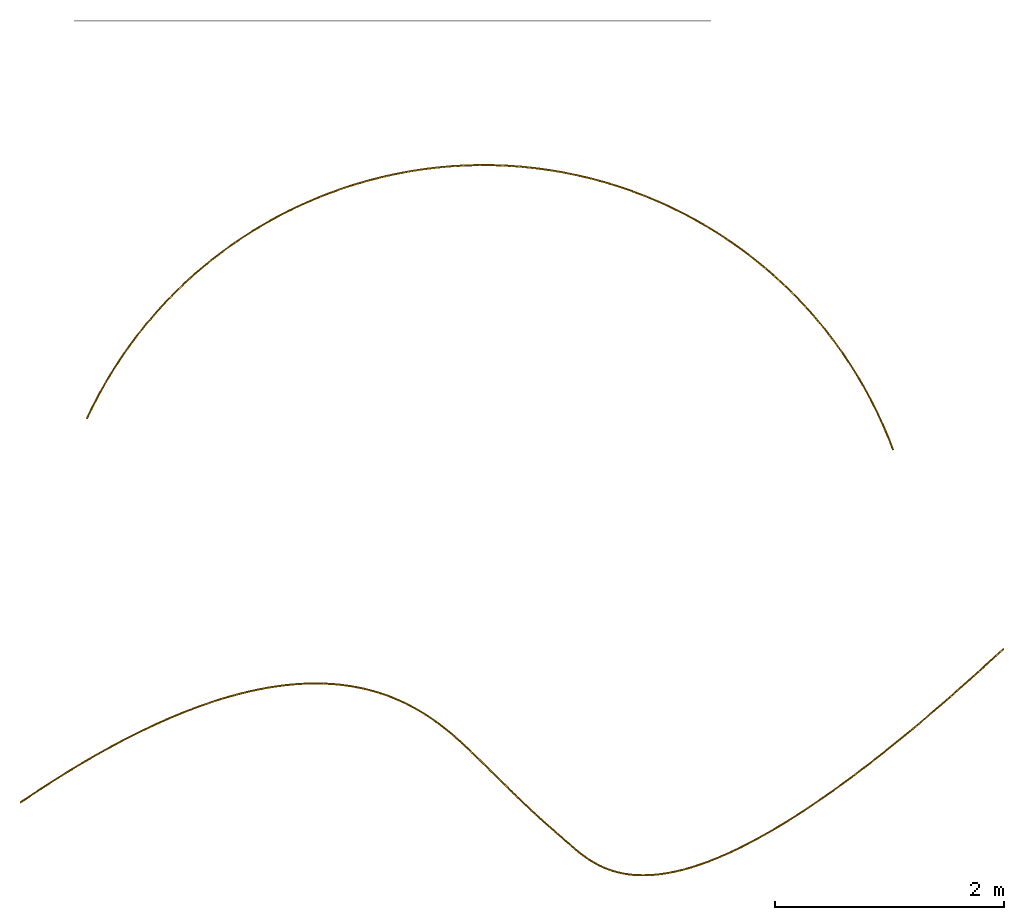
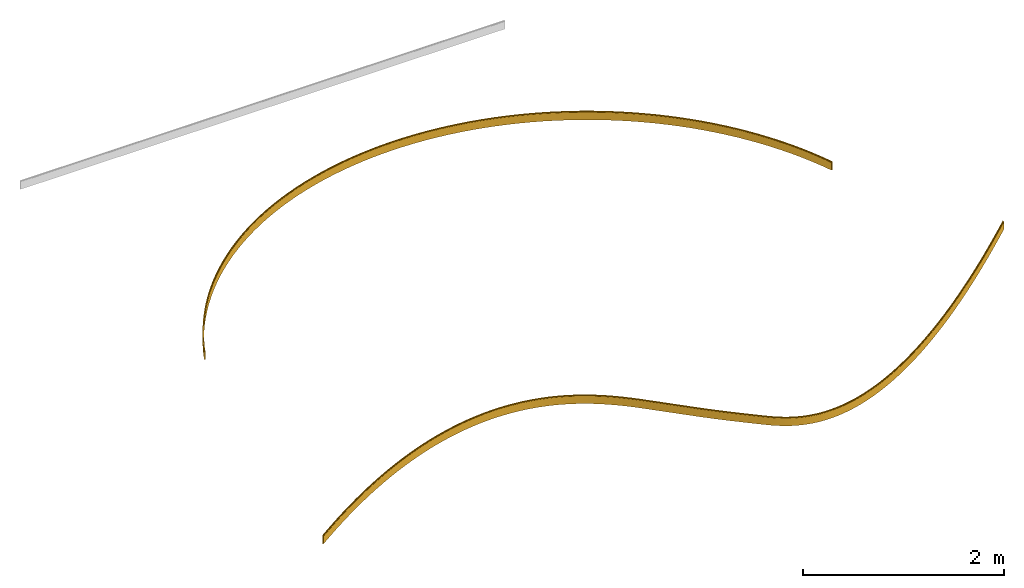
# One storey, part 1 of 2: 2 coverings.
"""IFC2X3 building model written with IfcOpenShell, lengths in feet."""

from ifc_helpers import new_model, entity, si_unit, converted_unit, derived_unit, money_unit, direction, frame, origin_with_axes, place, context, subcontext, project, spatial, material, type_object, element, save


model = new_model("IFC2X3")

# Units and contexts
model_context = context("Model", 3, precision=1e-05, world=origin_with_axes(), true_north=direction((0.0, 1.0)))
body_context = subcontext(model_context, "Body", "Model", "MODEL_VIEW", scale=1.0)
ifc_project = project(units=[converted_unit("LENGTHUNIT", "foot", entity("IfcReal", 30.48), si_unit("LENGTHUNIT", "METRE", prefix="CENTI"), dimensions=[1, 0, 0, 0, 0, 0, 0]), si_unit("AREAUNIT", "SQUARE_METRE"), si_unit("VOLUMEUNIT", "CUBIC_METRE"), si_unit("ABSORBEDDOSEUNIT", "GRAY"), si_unit("AMOUNTOFSUBSTANCEUNIT", "MOLE"), si_unit("DOSEEQUIVALENTUNIT", "SIEVERT"), si_unit("ELECTRICCAPACITANCEUNIT", "FARAD"), si_unit("ELECTRICCHARGEUNIT", "COULOMB"), si_unit("ELECTRICCONDUCTANCEUNIT", "SIEMENS"), si_unit("ELECTRICCURRENTUNIT", "AMPERE"), si_unit("ELECTRICRESISTANCEUNIT", "OHM"), si_unit("ELECTRICVOLTAGEUNIT", "VOLT"), si_unit("ENERGYUNIT", "JOULE"), si_unit("FORCEUNIT", "NEWTON"), si_unit("FREQUENCYUNIT", "HERTZ"), si_unit("ILLUMINANCEUNIT", "LUX"), si_unit("INDUCTANCEUNIT", "HENRY"), si_unit("LUMINOUSFLUXUNIT", "LUMEN"), si_unit("LUMINOUSINTENSITYUNIT", "CANDELA"), si_unit("MAGNETICFLUXDENSITYUNIT", "TESLA"), si_unit("MAGNETICFLUXUNIT", "WEBER"), si_unit("MASSUNIT", "GRAM"), converted_unit("PLANEANGLEUNIT", "degree", entity("IfcReal", 0.0174532925199433), si_unit("PLANEANGLEUNIT", "RADIAN"), dimensions=[0, 0, 0, 0, 0, 0, 0]), si_unit("POWERUNIT", "WATT"), si_unit("PRESSUREUNIT", "PASCAL"), si_unit("RADIOACTIVITYUNIT", "BECQUEREL"), si_unit("SOLIDANGLEUNIT", "STERADIAN"), si_unit("THERMODYNAMICTEMPERATUREUNIT", "KELVIN"), si_unit("TIMEUNIT", "SECOND"), derived_unit("ACCELERATIONUNIT", [(converted_unit("LENGTHUNIT", "foot", entity("IfcReal", 30.48), si_unit("LENGTHUNIT", "METRE", prefix="CENTI"), dimensions=[1, 0, 0, 0, 0, 0, 0]), 1), (si_unit("TIMEUNIT", "SECOND"), -2)]), derived_unit("ANGULARVELOCITYUNIT", [(converted_unit("PLANEANGLEUNIT", "degree", entity("IfcReal", 0.0174532925199433), si_unit("PLANEANGLEUNIT", "RADIAN"), dimensions=[0, 0, 0, 0, 0, 0, 0]), 1), (si_unit("TIMEUNIT", "SECOND"), -1)]), derived_unit("CURVATUREUNIT", [(converted_unit("PLANEANGLEUNIT", "degree", entity("IfcReal", 0.0174532925199433), si_unit("PLANEANGLEUNIT", "RADIAN"), dimensions=[0, 0, 0, 0, 0, 0, 0]), 1), (converted_unit("LENGTHUNIT", "foot", entity("IfcReal", 30.48), si_unit("LENGTHUNIT", "METRE", prefix="CENTI"), dimensions=[1, 0, 0, 0, 0, 0, 0]), -1)]), derived_unit("DYNAMICVISCOSITYUNIT", [(si_unit("PRESSUREUNIT", "PASCAL"), 1), (si_unit("TIMEUNIT", "SECOND"), 1)]), derived_unit("HEATFLUXDENSITYUNIT", [(si_unit("POWERUNIT", "WATT"), 1), (converted_unit("LENGTHUNIT", "foot", entity("IfcReal", 30.48), si_unit("LENGTHUNIT", "METRE", prefix="CENTI"), dimensions=[1, 0, 0, 0, 0, 0, 0]), -2)]), derived_unit("HEATINGVALUEUNIT", [(si_unit("ENERGYUNIT", "JOULE"), 1), (si_unit("MASSUNIT", "GRAM"), -1)]), derived_unit("INTEGERCOUNTRATEUNIT", [(si_unit("TIMEUNIT", "SECOND"), -1)]), derived_unit("IONCONCENTRATIONUNIT", [(si_unit("MASSUNIT", "GRAM"), 1), (si_unit("VOLUMEUNIT", "CUBIC_METRE"), -1)]), derived_unit("ISOTHERMALMOISTURECAPACITYUNIT", [(si_unit("VOLUMEUNIT", "CUBIC_METRE"), 1), (si_unit("MASSUNIT", "GRAM"), -1)]), derived_unit("KINEMATICVISCOSITYUNIT", [(si_unit("AREAUNIT", "SQUARE_METRE"), 1), (si_unit("TIMEUNIT", "SECOND"), -1)]), derived_unit("LINEARFORCEUNIT", [(si_unit("FORCEUNIT", "NEWTON"), 1), (converted_unit("LENGTHUNIT", "foot", entity("IfcReal", 30.48), si_unit("LENGTHUNIT", "METRE", prefix="CENTI"), dimensions=[1, 0, 0, 0, 0, 0, 0]), -1)]), derived_unit("LINEARMOMENTUNIT", [(si_unit("FORCEUNIT", "NEWTON"), 1), (converted_unit("LENGTHUNIT", "foot", entity("IfcReal", 30.48), si_unit("LENGTHUNIT", "METRE", prefix="CENTI"), dimensions=[1, 0, 0, 0, 0, 0, 0]), -1)]), derived_unit("LINEARSTIFFNESSUNIT", [(si_unit("FORCEUNIT", "NEWTON"), 1), (converted_unit("LENGTHUNIT", "foot", entity("IfcReal", 30.48), si_unit("LENGTHUNIT", "METRE", prefix="CENTI"), dimensions=[1, 0, 0, 0, 0, 0, 0]), -1)]), derived_unit("LINEARVELOCITYUNIT", [(converted_unit("LENGTHUNIT", "foot", entity("IfcReal", 30.48), si_unit("LENGTHUNIT", "METRE", prefix="CENTI"), dimensions=[1, 0, 0, 0, 0, 0, 0]), 1), (si_unit("TIMEUNIT", "SECOND"), -1)]), derived_unit("LUMINOUSINTENSITYDISTRIBUTIONUNIT", [(si_unit("LUMINOUSINTENSITYUNIT", "CANDELA"), 1), (si_unit("LUMINOUSFLUXUNIT", "LUMEN"), -1)]), derived_unit("MASSDENSITYUNIT", [(si_unit("MASSUNIT", "GRAM"), 1), (si_unit("VOLUMEUNIT", "CUBIC_METRE"), -1)]), derived_unit("MASSFLOWRATEUNIT", [(si_unit("MASSUNIT", "GRAM"), 1), (si_unit("TIMEUNIT", "SECOND"), -1)]), derived_unit("MASSPERLENGTHUNIT", [(si_unit("MASSUNIT", "GRAM"), 1), (converted_unit("LENGTHUNIT", "foot", entity("IfcReal", 30.48), si_unit("LENGTHUNIT", "METRE", prefix="CENTI"), dimensions=[1, 0, 0, 0, 0, 0, 0]), -1)]), derived_unit("MODULUSOFELASTICITYUNIT", [(si_unit("FORCEUNIT", "NEWTON"), 1), (si_unit("AREAUNIT", "SQUARE_METRE"), -1)]), derived_unit("MODULUSOFLINEARSUBGRADEREACTIONUNIT", [(si_unit("FORCEUNIT", "NEWTON"), 1), (converted_unit("LENGTHUNIT", "foot", entity("IfcReal", 30.48), si_unit("LENGTHUNIT", "METRE", prefix="CENTI"), dimensions=[1, 0, 0, 0, 0, 0, 0]), -2)]), derived_unit("MODULUSOFROTATIONALSUBGRADEREACTIONUNIT", [(si_unit("FORCEUNIT", "NEWTON"), 1), (converted_unit("LENGTHUNIT", "foot", entity("IfcReal", 30.48), si_unit("LENGTHUNIT", "METRE", prefix="CENTI"), dimensions=[1, 0, 0, 0, 0, 0, 0]), 1)]), derived_unit("MODULUSOFSUBGRADEREACTIONUNIT", [(si_unit("FORCEUNIT", "NEWTON"), 1), (si_unit("VOLUMEUNIT", "CUBIC_METRE"), -1)]), derived_unit("MOISTUREDIFFUSIVITYUNIT", [(si_unit("VOLUMEUNIT", "CUBIC_METRE"), 1), (si_unit("TIMEUNIT", "SECOND"), -1)]), derived_unit("MOLECULARWEIGHTUNIT", [(si_unit("MASSUNIT", "GRAM"), 1), (si_unit("AMOUNTOFSUBSTANCEUNIT", "MOLE"), -1)]), derived_unit("PLANARFORCEUNIT", [(si_unit("FORCEUNIT", "NEWTON"), 1), (converted_unit("LENGTHUNIT", "foot", entity("IfcReal", 30.48), si_unit("LENGTHUNIT", "METRE", prefix="CENTI"), dimensions=[1, 0, 0, 0, 0, 0, 0]), -2)]), derived_unit("ROTATIONALFREQUENCYUNIT", [(si_unit("TIMEUNIT", "SECOND"), -1)]), derived_unit("ROTATIONALMASSUNIT", [(si_unit("MASSUNIT", "GRAM"), 1), (converted_unit("LENGTHUNIT", "foot", entity("IfcReal", 30.48), si_unit("LENGTHUNIT", "METRE", prefix="CENTI"), dimensions=[1, 0, 0, 0, 0, 0, 0]), 2)]), derived_unit("ROTATIONALSTIFFNESSUNIT", [(si_unit("FORCEUNIT", "NEWTON"), 1), (converted_unit("LENGTHUNIT", "foot", entity("IfcReal", 30.48), si_unit("LENGTHUNIT", "METRE", prefix="CENTI"), dimensions=[1, 0, 0, 0, 0, 0, 0]), 1), (converted_unit("PLANEANGLEUNIT", "degree", entity("IfcReal", 0.0174532925199433), si_unit("PLANEANGLEUNIT", "RADIAN"), dimensions=[0, 0, 0, 0, 0, 0, 0]), -1)]), derived_unit("SECTIONAREAINTEGRALUNIT", [(converted_unit("LENGTHUNIT", "foot", entity("IfcReal", 30.48), si_unit("LENGTHUNIT", "METRE", prefix="CENTI"), dimensions=[1, 0, 0, 0, 0, 0, 0]), 5)]), derived_unit("SECTIONMODULUSUNIT", [(converted_unit("LENGTHUNIT", "foot", entity("IfcReal", 30.48), si_unit("LENGTHUNIT", "METRE", prefix="CENTI"), dimensions=[1, 0, 0, 0, 0, 0, 0]), 3)]), derived_unit("SHEARMODULUSUNIT", [(si_unit("FORCEUNIT", "NEWTON"), 1), (si_unit("AREAUNIT", "SQUARE_METRE"), -1)]), derived_unit("SOUNDPOWERUNIT", [(si_unit("ENERGYUNIT", "JOULE"), 1), (si_unit("TIMEUNIT", "SECOND"), -1)]), derived_unit("SPECIFICHEATCAPACITYUNIT", [(si_unit("FORCEUNIT", "NEWTON"), 1), (si_unit("MASSUNIT", "GRAM"), -1), (si_unit("THERMODYNAMICTEMPERATUREUNIT", "KELVIN"), -1)]), derived_unit("TEMPERATUREGRADIENTUNIT", [(si_unit("THERMODYNAMICTEMPERATUREUNIT", "KELVIN"), 1), (converted_unit("LENGTHUNIT", "foot", entity("IfcReal", 30.48), si_unit("LENGTHUNIT", "METRE", prefix="CENTI"), dimensions=[1, 0, 0, 0, 0, 0, 0]), -1)]), derived_unit("THERMALADMITTANCEUNIT", [(si_unit("POWERUNIT", "WATT"), 1), (si_unit("AREAUNIT", "SQUARE_METRE"), -1), (si_unit("THERMODYNAMICTEMPERATUREUNIT", "KELVIN"), -1)]), derived_unit("THERMALCONDUCTANCEUNIT", [(si_unit("POWERUNIT", "WATT"), 1), (converted_unit("LENGTHUNIT", "foot", entity("IfcReal", 30.48), si_unit("LENGTHUNIT", "METRE", prefix="CENTI"), dimensions=[1, 0, 0, 0, 0, 0, 0]), -1), (si_unit("THERMODYNAMICTEMPERATUREUNIT", "KELVIN"), -1)]), derived_unit("THERMALEXPANSIONCOEFFICIENTUNIT", [(si_unit("THERMODYNAMICTEMPERATUREUNIT", "KELVIN"), -1)]), derived_unit("THERMALRESISTANCEUNIT", [(si_unit("AREAUNIT", "SQUARE_METRE"), 1), (si_unit("POWERUNIT", "WATT"), -1)]), derived_unit("THERMALTRANSMITTANCEUNIT", [(si_unit("POWERUNIT", "WATT"), 1), (si_unit("AREAUNIT", "SQUARE_METRE"), -1), (si_unit("THERMODYNAMICTEMPERATUREUNIT", "KELVIN"), -1)]), derived_unit("TORQUEUNIT", [(si_unit("FORCEUNIT", "NEWTON"), 1), (converted_unit("LENGTHUNIT", "foot", entity("IfcReal", 30.48), si_unit("LENGTHUNIT", "METRE", prefix="CENTI"), dimensions=[1, 0, 0, 0, 0, 0, 0]), 1)]), derived_unit("VAPORPERMEABILITYUNIT", [(si_unit("MASSUNIT", "GRAM"), 1), (si_unit("TIMEUNIT", "SECOND"), -1)]), derived_unit("VOLUMETRICFLOWRATEUNIT", [(si_unit("VOLUMEUNIT", "CUBIC_METRE"), 1), (si_unit("TIMEUNIT", "SECOND"), -1)]), derived_unit("WARPINGCONSTANTUNIT", [(converted_unit("LENGTHUNIT", "foot", entity("IfcReal", 30.48), si_unit("LENGTHUNIT", "METRE", prefix="CENTI"), dimensions=[1, 0, 0, 0, 0, 0, 0]), 6)]), derived_unit("WARPINGMOMENTUNIT", [(si_unit("FORCEUNIT", "NEWTON"), 1), (converted_unit("LENGTHUNIT", "foot", entity("IfcReal", 30.48), si_unit("LENGTHUNIT", "METRE", prefix="CENTI"), dimensions=[1, 0, 0, 0, 0, 0, 0]), 2)]), money_unit("USD")], contexts=[model_context])

# Site, building, storey
site_placement = place(None, origin_with_axes())
site = spatial("IfcSite", under=ifc_project, at=site_placement, CompositionType="ELEMENT")
building_placement = place(site_placement, origin_with_axes())
building = spatial("IfcBuilding", under=site, at=building_placement, Name="Bldg 1", CompositionType="ELEMENT")
storey_placement = place(building_placement, origin_with_axes())
storey = spatial("IfcBuildingStorey", under=building, at=storey_placement, Name="Floor 1", CompositionType="ELEMENT", Elevation=0.0)

# Coverings
ifc_material = material(Name="WallBase")
covering_type = type_object("IfcCoveringType", Name="Base Molding", PredefinedType="NOTDEFINED")
covering_1_placement = place(storey_placement, frame((-18.032886, 24.565833, 0.323846), z_axis=(0.42012271, 0.90746731, 0.0), x_axis=(0.90746731, -0.42012271, 0.0)))
cartesian_point_1 = entity("IfcCartesianPoint", [0.028266, 0.019235])
cartesian_point_2 = entity("IfcCartesianPoint", [0.028266, 0.323846])
cartesian_point_3 = entity("IfcCartesianPoint", [-0.013401, 0.323846])
cartesian_point_4 = entity("IfcCartesianPoint", [-0.013401, -0.009487])
cartesian_point_5 = entity("IfcCartesianPoint", [0.0, -0.009487])
element("IfcCovering", 1, at=covering_1_placement, inside=storey, type_object=covering_type, material=ifc_material, Name="Base Molding", ObjectType="Base Molding", PredefinedType="NOTDEFINED", context=body_context, shape_type="SweptSolid", body=[
    entity("IfcRevolvedAreaSolid", entity("IfcArbitraryClosedProfileDef", "AREA", None, entity("IfcCompositeCurve", [entity("IfcCompositeCurveSegment", "CONTINUOUS", True, entity("IfcTrimmedCurve", entity("IfcCircle", entity("IfcAxis2Placement2D", entity("IfcCartesianPoint", [0.0, 0.019235]), entity("IfcDirection", [1.0, 0.0])), 0.019235), [entity("IfcParameterValue", 270.0)], [entity("IfcParameterValue", 360.0)], True, "PARAMETER")), entity("IfcCompositeCurveSegment", "CONTINUOUS", True, entity("IfcPolyline", [entity("IfcCartesianPoint", [0.019235, 0.019235]), cartesian_point_1])), entity("IfcCompositeCurveSegment", "CONTINUOUS", True, entity("IfcPolyline", [cartesian_point_1, cartesian_point_2])), entity("IfcCompositeCurveSegment", "CONTINUOUS", True, entity("IfcPolyline", [cartesian_point_2, cartesian_point_3])), entity("IfcCompositeCurveSegment", "CONTINUOUS", True, entity("IfcPolyline", [cartesian_point_3, cartesian_point_4])), entity("IfcCompositeCurveSegment", "CONTINUOUS", True, entity("IfcPolyline", [cartesian_point_4, cartesian_point_5])), entity("IfcCompositeCurveSegment", "CONTINUOUS", True, entity("IfcPolyline", [cartesian_point_5, entity("IfcCartesianPoint", [0.0, 0.0])]))], False)), entity("IfcAxis2Placement3D", entity("IfcCartesianPoint", [0.0, 0.0, 0.0]), entity("IfcDirection", [0.0, 0.0, 1.0]), entity("IfcDirection", [1.0, 0.0, 0.0])), entity("IfcAxis1Placement", entity("IfcCartesianPoint", [12.540917, 0.323846, 0.0]), entity("IfcDirection", [0.0, 1.0, 0.0])), 134.773678517696),
])
covering_2_placement = place(storey_placement, frame((-19.937296, 13.554455, 0.323846), z_axis=(0.82589822, 0.56381924, 0.0), x_axis=(0.56381924, -0.82589822, 0.0)))
cartesian_point_6 = entity("IfcCartesianPoint", [0.304611, 0.041667])
cartesian_point_7 = entity("IfcCartesianPoint", [0.0, 0.041667])
cartesian_point_8 = entity("IfcCartesianPoint", [0.0, 0.0])
cartesian_point_9 = entity("IfcCartesianPoint", [0.333333, 0.0])
cartesian_point_10 = entity("IfcCartesianPoint", [0.333333, 0.013401])
ifc_direction_1 = entity("IfcDirection", [1.0, 0.0, 0.0])
ifc_direction_2 = entity("IfcDirection", [0.0, 1.0, 0.0])
ifc_direction_3 = entity("IfcDirection", [0.0, -1.0, 0.0])
ifc_direction_4 = entity("IfcDirection", [-0.96300246, 0.0, 0.2694926])
ifc_direction_5 = entity("IfcDirection", [-0.90981211, 0.0, 0.41502039])
ifc_direction_6 = entity("IfcDirection", [-0.46499282, 0.0, 0.88531445])
ifc_direction_7 = entity("IfcDirection", [-0.23169356, 0.0, 0.97278882])
ifc_direction_8 = entity("IfcDirection", [0.68534679, 0.0, -0.72821684])
ifc_direction_9 = entity("IfcDirection", [0.84503501, 0.0, -0.53471098])
ifc_direction_10 = entity("IfcDirection", [0.98301975, 0.0, -0.1834998])
ifc_direction_11 = entity("IfcDirection", [0.99225817, 0.0, 0.12419231])
element("IfcCovering", 2, at=covering_2_placement, inside=storey, type_object=covering_type, material=ifc_material, Name="Base Molding", ObjectType="Base Molding", PredefinedType="NOTDEFINED", context=body_context, shape_type="SweptSolid", body=[
    entity("IfcSurfaceCurveSweptAreaSolid", entity("IfcArbitraryClosedProfileDef", "AREA", None, entity("IfcCompositeCurve", [entity("IfcCompositeCurveSegment", "CONTINUOUS", True, entity("IfcTrimmedCurve", entity("IfcCircle", entity("IfcAxis2Placement2D", entity("IfcCartesianPoint", [0.304611, 0.013401]), entity("IfcDirection", [0.0, 1.0])), 0.019235), [entity("IfcParameterValue", 270.0)], [entity("IfcParameterValue", 360.0)], True, "PARAMETER")), entity("IfcCompositeCurveSegment", "CONTINUOUS", True, entity("IfcPolyline", [entity("IfcCartesianPoint", [0.304611, 0.032635]), cartesian_point_6])), entity("IfcCompositeCurveSegment", "CONTINUOUS", True, entity("IfcPolyline", [cartesian_point_6, cartesian_point_7])), entity("IfcCompositeCurveSegment", "CONTINUOUS", True, entity("IfcPolyline", [cartesian_point_7, cartesian_point_8])), entity("IfcCompositeCurveSegment", "CONTINUOUS", True, entity("IfcPolyline", [cartesian_point_8, cartesian_point_9])), entity("IfcCompositeCurveSegment", "CONTINUOUS", True, entity("IfcPolyline", [cartesian_point_9, cartesian_point_10])), entity("IfcCompositeCurveSegment", "CONTINUOUS", True, entity("IfcPolyline", [cartesian_point_10, entity("IfcCartesianPoint", [0.323846, 0.013401])]))], False)), entity("IfcAxis2Placement3D", entity("IfcCartesianPoint", [0.0, 0.0, 0.0]), entity("IfcDirection", [0.0, 0.0, 1.0]), ifc_direction_1), entity("IfcCompositeCurve", [entity("IfcCompositeCurveSegment", "CONTSAMEGRADIENT", True, entity("IfcTrimmedCurve", entity("IfcCircle", entity("IfcAxis2Placement3D", entity("IfcCartesianPoint", [35.108121, 0.323846, 0.0]), ifc_direction_2, entity("IfcDirection", [-1.0, 0.0, 0.0])), 35.121522), [entity("IfcParameterValue", 0.0)], [entity("IfcParameterValue", 2.459591)], True, "PARAMETER")), entity("IfcCompositeCurveSegment", "CONTSAMEGRADIENT", True, entity("IfcTrimmedCurve", entity("IfcCircle", entity("IfcAxis2Placement3D", entity("IfcCartesianPoint", [26.752142, 0.323846, 0.358926]), ifc_direction_2, entity("IfcDirection", [-0.99907874, 0.0, 0.04291477])), 26.757838), [entity("IfcParameterValue", 0.0)], [entity("IfcParameterValue", 2.817957)], True, "PARAMETER")), entity("IfcCompositeCurveSegment", "CONTSAMEGRADIENT", True, entity("IfcTrimmedCurve", entity("IfcCircle", entity("IfcAxis2Placement3D", entity("IfcCartesianPoint", [23.328366, 0.323846, 0.675187]), ifc_direction_2, entity("IfcDirection", [-0.99576082, 0.0, 0.09198039])), 23.319486), [entity("IfcParameterValue", 0.0)], [entity("IfcParameterValue", 3.060463)], True, "PARAMETER")), entity("IfcCompositeCurveSegment", "CONTSAMEGRADIENT", True, entity("IfcTrimmedCurve", entity("IfcCircle", entity("IfcAxis2Placement3D", entity("IfcCartesianPoint", [17.787831, 0.323846, 1.487217]), ifc_direction_2, entity("IfcDirection", [-0.9894298, 0.0, 0.14501263])), 17.719761), [entity("IfcParameterValue", 0.0)], [entity("IfcParameterValue", 3.511025)], True, "PARAMETER")), entity("IfcCompositeCurveSegment", "CONTSAMEGRADIENT", True, entity("IfcTrimmedCurve", entity("IfcCircle", entity("IfcAxis2Placement3D", entity("IfcCartesianPoint", [15.583747, 0.323846, 1.949644]), ifc_direction_3, ifc_direction_4), 15.467689), [entity("IfcParameterValue", 3.78504)], [entity("IfcParameterValue", 0.0)], False, "PARAMETER")), entity("IfcCompositeCurveSegment", "CONTSAMEGRADIENT", True, entity("IfcTrimmedCurve", entity("IfcCircle", entity("IfcAxis2Placement3D", entity("IfcCartesianPoint", [12.141578, 0.323846, 2.912922]), ifc_direction_2, ifc_direction_4), 11.893276), [entity("IfcParameterValue", 0.0)], [entity("IfcParameterValue", 4.316743)], True, "PARAMETER")), entity("IfcCompositeCurveSegment", "CONTSAMEGRADIENT", True, entity("IfcTrimmedCurve", entity("IfcCircle", entity("IfcAxis2Placement3D", entity("IfcCartesianPoint", [10.82821, 0.323846, 3.389672]), ifc_direction_3, ifc_direction_5), 10.496055), [entity("IfcParameterValue", 4.569781)], [entity("IfcParameterValue", 0.0)], False, "PARAMETER")), entity("IfcCompositeCurveSegment", "CONTSAMEGRADIENT", True, entity("IfcTrimmedCurve", entity("IfcCircle", entity("IfcAxis2Placement3D", entity("IfcCartesianPoint", [8.882218, 0.323846, 4.277357]), ifc_direction_2, ifc_direction_5), 8.35716), [entity("IfcParameterValue", 0.0)], [entity("IfcParameterValue", 5.121635)], True, "PARAMETER")), entity("IfcCompositeCurveSegment", "CONTSAMEGRADIENT", True, entity("IfcTrimmedCurve", entity("IfcCircle", entity("IfcAxis2Placement3D", entity("IfcCartesianPoint", [8.187719, 0.323846, 4.672564]), ifc_direction_3, entity("IfcDirection", [-0.82030714, 0.0, 0.57192325])), 7.558088), [entity("IfcParameterValue", 5.242213)], [entity("IfcParameterValue", 0.0)], False, "PARAMETER")), entity("IfcCompositeCurveSegment", "CONTSAMEGRADIENT", True, entity("IfcTrimmedCurve", entity("IfcCircle", entity("IfcAxis2Placement3D", entity("IfcCartesianPoint", [7.249058, 0.323846, 5.327005]), ifc_direction_3, entity("IfcDirection", [-0.75954992, 0.0, 0.65044901])), 6.413807), [entity("IfcParameterValue", 5.691015)], [entity("IfcParameterValue", 0.0)], False, "PARAMETER")), entity("IfcCompositeCurveSegment", "CONTSAMEGRADIENT", True, entity("IfcTrimmedCurve", entity("IfcCircle", entity("IfcAxis2Placement3D", entity("IfcCartesianPoint", [6.957333, 0.323846, 5.576827]), ifc_direction_3, entity("IfcDirection", [-0.69327343, 0.0, 0.72067465])), 6.029731), [entity("IfcParameterValue", 5.534745)], [entity("IfcParameterValue", 0.0)], False, "PARAMETER")), entity("IfcCompositeCurveSegment", "CONTSAMEGRADIENT", True, entity("IfcTrimmedCurve", entity("IfcCircle", entity("IfcAxis2Placement3D", entity("IfcCartesianPoint", [6.649139, 0.323846, 5.897202]), ifc_direction_3, entity("IfcDirection", [-0.61756889, 0.0, 0.7865168])), 5.585182), [entity("IfcParameterValue", 5.750973)], [entity("IfcParameterValue", 0.0)], False, "PARAMETER")), entity("IfcCompositeCurveSegment", "CONTSAMEGRADIENT", True, entity("IfcTrimmedCurve", entity("IfcCircle", entity("IfcAxis2Placement3D", entity("IfcCartesianPoint", [6.598612, 0.323846, 5.961552]), ifc_direction_3, entity("IfcDirection", [-0.54316622, 0.0, 0.83962519])), 5.503366), [entity("IfcParameterValue", 5.23938)], [entity("IfcParameterValue", 0.0)], False, "PARAMETER")), entity("IfcCompositeCurveSegment", "CONTSAMEGRADIENT", True, entity("IfcTrimmedCurve", entity("IfcCircle", entity("IfcAxis2Placement3D", entity("IfcCartesianPoint", [6.656098, 0.323846, 5.87269]), ifc_direction_3, ifc_direction_6), 5.609202), [entity("IfcParameterValue", 5.189681)], [entity("IfcParameterValue", 0.0)], False, "PARAMETER")), entity("IfcCompositeCurveSegment", "CONTSAMEGRADIENT", True, entity("IfcTrimmedCurve", entity("IfcCircle", entity("IfcAxis2Placement3D", entity("IfcCartesianPoint", [6.74033, 0.323846, 5.712317]), ifc_direction_2, ifc_direction_6), 5.790349), [entity("IfcParameterValue", 0.0)], [entity("IfcParameterValue", 4.37391)], True, "PARAMETER")), entity("IfcCompositeCurveSegment", "CONTSAMEGRADIENT", True, entity("IfcTrimmedCurve", entity("IfcCircle", entity("IfcAxis2Placement3D", entity("IfcCartesianPoint", [7.022464, 0.323846, 5.058336]), ifc_direction_3, entity("IfcDirection", [-0.3290073, 0.0, 0.94432738])), 6.502593), [entity("IfcParameterValue", 4.127313)], [entity("IfcParameterValue", 0.0)], False, "PARAMETER")), entity("IfcCompositeCurveSegment", "CONTSAMEGRADIENT", True, entity("IfcTrimmedCurve", entity("IfcCircle", entity("IfcAxis2Placement3D", entity("IfcCartesianPoint", [7.198835, 0.323846, 4.552111]), ifc_direction_3, entity("IfcDirection", [-0.27744486, 0.0, 0.96074156])), 7.038662), [entity("IfcParameterValue", 3.100769)], [entity("IfcParameterValue", 0.0)], False, "PARAMETER")), entity("IfcCompositeCurveSegment", "CONTSAMEGRADIENT", True, entity("IfcTrimmedCurve", entity("IfcCircle", entity("IfcAxis2Placement3D", entity("IfcCartesianPoint", [7.800651, 0.323846, 2.468131]), ifc_direction_3, ifc_direction_7), 9.207799), [entity("IfcParameterValue", 2.710966)], [entity("IfcParameterValue", 0.0)], False, "PARAMETER")), entity("IfcCompositeCurveSegment", "CONTSAMEGRADIENT", True, entity("IfcTrimmedCurve", entity("IfcCircle", entity("IfcAxis2Placement3D", entity("IfcCartesianPoint", [8.001574, 0.323846, 1.624534]), ifc_direction_2, ifc_direction_7), 10.074994), [entity("IfcParameterValue", 0.0)], [entity("IfcParameterValue", 1.453392)], True, "PARAMETER")), entity("IfcCompositeCurveSegment", "CONTSAMEGRADIENT", True, entity("IfcTrimmedCurve", entity("IfcCircle", entity("IfcAxis2Placement3D", entity("IfcCartesianPoint", [12.519503, 0.323846, -19.734366]), ifc_direction_2, entity("IfcDirection", [-0.20694545, 0.0, 0.97835248])), 31.906491), [entity("IfcParameterValue", 0.0)], [entity("IfcParameterValue", 0.816691)], True, "PARAMETER")), entity("IfcCompositeCurveSegment", "CONTSAMEGRADIENT", True, entity("IfcTrimmedCurve", entity("IfcCircle", entity("IfcAxis2Placement3D", entity("IfcCartesianPoint", [-103.386262, 0.323846, 569.587562]), ifc_direction_3, entity("IfcDirection", [0.19297952, 0.0, -0.98120279])), 568.705265), [entity("IfcParameterValue", 0.0)], [entity("IfcParameterValue", 0.121228)], True, "PARAMETER")), entity("IfcCompositeCurveSegment", "CONTSAMEGRADIENT", True, entity("IfcTrimmedCurve", entity("IfcCircle", entity("IfcAxis2Placement3D", entity("IfcCartesianPoint", [-3.196435, 0.323846, 65.804834]), ifc_direction_3, entity("IfcDirection", [0.19505514, 0.0, -0.98079228])), 55.056514), [entity("IfcParameterValue", 0.0)], [entity("IfcParameterValue", 0.389621)], True, "PARAMETER")), entity("IfcCompositeCurveSegment", "CONTSAMEGRADIENT", True, entity("IfcTrimmedCurve", entity("IfcCircle", entity("IfcAxis2Placement3D", entity("IfcCartesianPoint", [1.318913, 0.323846, 43.880759]), ifc_direction_3, entity("IfcDirection", [0.20172013, 0.0, -0.9794432])), 32.672292), [entity("IfcParameterValue", 0.0)], [entity("IfcParameterValue", 0.91909)], True, "PARAMETER")), entity("IfcCompositeCurveSegment", "CONTSAMEGRADIENT", True, entity("IfcTrimmedCurve", entity("IfcCircle", entity("IfcAxis2Placement3D", entity("IfcCartesianPoint", [4.025934, 0.323846, 31.727061]), ifc_direction_3, entity("IfcDirection", [0.2174049, 0.0, -0.97608151])), 20.220772), [entity("IfcParameterValue", 0.0)], [entity("IfcParameterValue", 1.168293)], True, "PARAMETER")), entity("IfcCompositeCurveSegment", "CONTSAMEGRADIENT", True, entity("IfcTrimmedCurve", entity("IfcCircle", entity("IfcAxis2Placement3D", entity("IfcCartesianPoint", [3.19366, 0.323846, 35.134738]), ifc_direction_3, entity("IfcDirection", [0.23726118, 0.0, -0.9714459])), 23.728612), [entity("IfcParameterValue", 0.0)], [entity("IfcParameterValue", 0.711194)], True, "PARAMETER")), entity("IfcCompositeCurveSegment", "CONTSAMEGRADIENT", True, entity("IfcTrimmedCurve", entity("IfcCircle", entity("IfcAxis2Placement3D", entity("IfcCartesianPoint", [-34.984495, 0.323846, 183.440381]), ifc_direction_3, entity("IfcDirection", [0.24930084, 0.0, -0.96842609])), 176.869513), [entity("IfcParameterValue", 0.0)], [entity("IfcParameterValue", 0.260493)], True, "PARAMETER")), entity("IfcCompositeCurveSegment", "CONTSAMEGRADIENT", True, entity("IfcTrimmedCurve", entity("IfcCircle", entity("IfcAxis2Placement3D", entity("IfcCartesianPoint", [6.929937, 0.323846, 23.633843]), ifc_direction_3, entity("IfcDirection", [0.25370115, 0.0, -0.96728265])), 11.657681), [entity("IfcParameterValue", 0.0)], [entity("IfcParameterValue", 1.49341)], True, "PARAMETER")), entity("IfcCompositeCurveSegment", "CONTSAMEGRADIENT", True, entity("IfcTrimmedCurve", entity("IfcCircle", entity("IfcAxis2Placement3D", entity("IfcCartesianPoint", [9.150396, 0.323846, 15.986015]), ifc_direction_3, entity("IfcDirection", [0.27882427, 0.0, -0.96034214])), 3.694032), [entity("IfcParameterValue", 0.0)], [entity("IfcParameterValue", 2.653148)], True, "PARAMETER")), entity("IfcCompositeCurveSegment", "CONTSAMEGRADIENT", True, entity("IfcTrimmedCurve", entity("IfcCircle", entity("IfcAxis2Placement3D", entity("IfcCartesianPoint", [9.245986, 0.323846, 15.705914]), ifc_direction_3, entity("IfcDirection", [0.32297926, 0.0, -0.94640604])), 3.398069), [entity("IfcParameterValue", 0.0)], [entity("IfcParameterValue", 4.90938)], True, "PARAMETER")), entity("IfcCompositeCurveSegment", "CONTSAMEGRADIENT", True, entity("IfcTrimmedCurve", entity("IfcCircle", entity("IfcAxis2Placement3D", entity("IfcCartesianPoint", [9.524029, 0.323846, 15.074089]), ifc_direction_3, entity("IfcDirection", [0.40278781, 0.0, -0.91529338])), 2.707771), [entity("IfcParameterValue", 0.0)], [entity("IfcParameterValue", 5.500101)], True, "PARAMETER")), entity("IfcCompositeCurveSegment", "CONTSAMEGRADIENT", True, entity("IfcTrimmedCurve", entity("IfcCircle", entity("IfcAxis2Placement3D", entity("IfcCartesianPoint", [9.575717, 0.323846, 14.981804]), ifc_direction_3, entity("IfcDirection", [0.48866198, 0.0, -0.87247319])), 2.601997), [entity("IfcParameterValue", 0.0)], [entity("IfcParameterValue", 7.029518)], True, "PARAMETER")), entity("IfcCompositeCurveSegment", "CONTSAMEGRADIENT", True, entity("IfcTrimmedCurve", entity("IfcCircle", entity("IfcAxis2Placement3D", entity("IfcCartesianPoint", [9.55413, 0.323846, 15.01121]), ifc_direction_2, ifc_direction_8), 2.638477), [entity("IfcParameterValue", 6.980693)], [entity("IfcParameterValue", 0.0)], False, "PARAMETER")), entity("IfcCompositeCurveSegment", "CONTSAMEGRADIENT", True, entity("IfcTrimmedCurve", entity("IfcCircle", entity("IfcAxis2Placement3D", entity("IfcCartesianPoint", [9.444853, 0.323846, 15.127323]), ifc_direction_3, ifc_direction_8), 2.797924), [entity("IfcParameterValue", 0.0)], [entity("IfcParameterValue", 7.56984)], True, "PARAMETER")), entity("IfcCompositeCurveSegment", "CONTSAMEGRADIENT", True, entity("IfcTrimmedCurve", entity("IfcCircle", entity("IfcAxis2Placement3D", entity("IfcCartesianPoint", [8.960236, 0.323846, 15.522106]), ifc_direction_2, ifc_direction_9), 3.42299), [entity("IfcParameterValue", 6.842961)], [entity("IfcParameterValue", 0.0)], False, "PARAMETER")), entity("IfcCompositeCurveSegment", "CONTSAMEGRADIENT", True, entity("IfcTrimmedCurve", entity("IfcCircle", entity("IfcAxis2Placement3D", entity("IfcCartesianPoint", [8.530767, 0.323846, 15.79386]), ifc_direction_3, ifc_direction_9), 3.931216), [entity("IfcParameterValue", 0.0)], [entity("IfcParameterValue", 6.648338)], True, "PARAMETER")), entity("IfcCompositeCurveSegment", "CONTSAMEGRADIENT", True, entity("IfcTrimmedCurve", entity("IfcCircle", entity("IfcAxis2Placement3D", entity("IfcCartesianPoint", [7.170335, 0.323846, 16.447889]), ifc_direction_3, entity("IfcDirection", [0.90125878, 0.0, -0.43328121])), 5.440696), [entity("IfcParameterValue", 0.0)], [entity("IfcParameterValue", 5.650432)], True, "PARAMETER")), entity("IfcCompositeCurveSegment", "CONTSAMEGRADIENT", True, entity("IfcTrimmedCurve", entity("IfcCircle", entity("IfcAxis2Placement3D", entity("IfcCartesianPoint", [6.161042, 0.323846, 16.815752]), ifc_direction_3, entity("IfcDirection", [0.93954005, 0.0, -0.34243904])), 6.514938), [entity("IfcParameterValue", 0.0)], [entity("IfcParameterValue", 5.167251)], True, "PARAMETER")), entity("IfcCompositeCurveSegment", "CONTSAMEGRADIENT", True, entity("IfcTrimmedCurve", entity("IfcCircle", entity("IfcAxis2Placement3D", entity("IfcCartesianPoint", [3.301322, 0.323846, 17.574436]), ifc_direction_2, ifc_direction_10), 9.473586), [entity("IfcParameterValue", 4.284612)], [entity("IfcParameterValue", 0.0)], False, "PARAMETER")), entity("IfcCompositeCurveSegment", "CONTSAMEGRADIENT", True, entity("IfcTrimmedCurve", entity("IfcCircle", entity("IfcAxis2Placement3D", entity("IfcCartesianPoint", [1.34885, 0.323846, 17.938903]), ifc_direction_3, ifc_direction_10), 11.459784), [entity("IfcParameterValue", 0.0)], [entity("IfcParameterValue", 3.827679)], True, "PARAMETER")), entity("IfcCompositeCurveSegment", "CONTSAMEGRADIENT", True, entity("IfcTrimmedCurve", entity("IfcCircle", entity("IfcAxis2Placement3D", entity("IfcCartesianPoint", [-3.847346, 0.323846, 18.553545]), ifc_direction_3, entity("IfcDirection", [0.99307666, 0.0, -0.11746809])), 16.692206), [entity("IfcParameterValue", 0.0)], [entity("IfcParameterValue", 3.17133)], True, "PARAMETER")), entity("IfcCompositeCurveSegment", "CONTSAMEGRADIENT", True, entity("IfcTrimmedCurve", entity("IfcCircle", entity("IfcAxis2Placement3D", entity("IfcCartesianPoint", [-7.215101, 0.323846, 18.763932]), ifc_direction_3, entity("IfcDirection", [0.99805439, 0.0, -0.06234931])), 20.066526), [entity("IfcParameterValue", 0.0)], [entity("IfcParameterValue", 2.823346)], True, "PARAMETER")), entity("IfcCompositeCurveSegment", "CONTSAMEGRADIENT", True, entity("IfcTrimmedCurve", entity("IfcCircle", entity("IfcAxis2Placement3D", entity("IfcCartesianPoint", [-15.8051, 0.323846, 18.87658]), ifc_direction_3, entity("IfcDirection", [0.99991402, 0.0, -0.01311272])), 28.657263), [entity("IfcParameterValue", 0.0)], [entity("IfcParameterValue", 2.362488)], True, "PARAMETER")), entity("IfcCompositeCurveSegment", "CONTSAMEGRADIENT", True, entity("IfcTrimmedCurve", entity("IfcCircle", entity("IfcAxis2Placement3D", entity("IfcCartesianPoint", [-21.172445, 0.323846, 18.72561]), ifc_direction_3, entity("IfcDirection", [0.99960466, 0.0, 0.02811639])), 34.026731), [entity("IfcParameterValue", 0.0)], [entity("IfcParameterValue", 2.113879)], True, "PARAMETER")), entity("IfcCompositeCurveSegment", "CONTSAMEGRADIENT", True, entity("IfcTrimmedCurve", entity("IfcCircle", entity("IfcAxis2Placement3D", entity("IfcCartesianPoint", [-34.439464, 0.323846, 17.861847]), ifc_direction_3, entity("IfcDirection", [0.99788732, 0.0, 0.06496845])), 47.321839), [entity("IfcParameterValue", 0.0)], [entity("IfcParameterValue", 1.792473)], True, "PARAMETER")), entity("IfcCompositeCurveSegment", "CONTSAMEGRADIENT", True, entity("IfcTrimmedCurve", entity("IfcCircle", entity("IfcAxis2Placement3D", entity("IfcCartesianPoint", [-42.505157, 0.323846, 17.082721]), ifc_direction_2, ifc_direction_11), 55.425076), [entity("IfcParameterValue", 1.616601)], [entity("IfcParameterValue", 0.0)], False, "PARAMETER")), entity("IfcCompositeCurveSegment", "DISCONTINUOUS", True, entity("IfcTrimmedCurve", entity("IfcCircle", entity("IfcAxis2Placement3D", entity("IfcCartesianPoint", [-61.962644, 0.323846, 14.647396]), ifc_direction_3, ifc_direction_11), 75.034375), [entity("IfcParameterValue", 0.0)], [entity("IfcParameterValue", 1.389383)], True, "PARAMETER"))], False), 0.0, 2.9019600857282, entity("IfcPlane", entity("IfcAxis2Placement3D", entity("IfcCartesianPoint", [0.0, 0.323846, 0.0]), ifc_direction_3, ifc_direction_1))),
])

save(model, "model.ifc")
